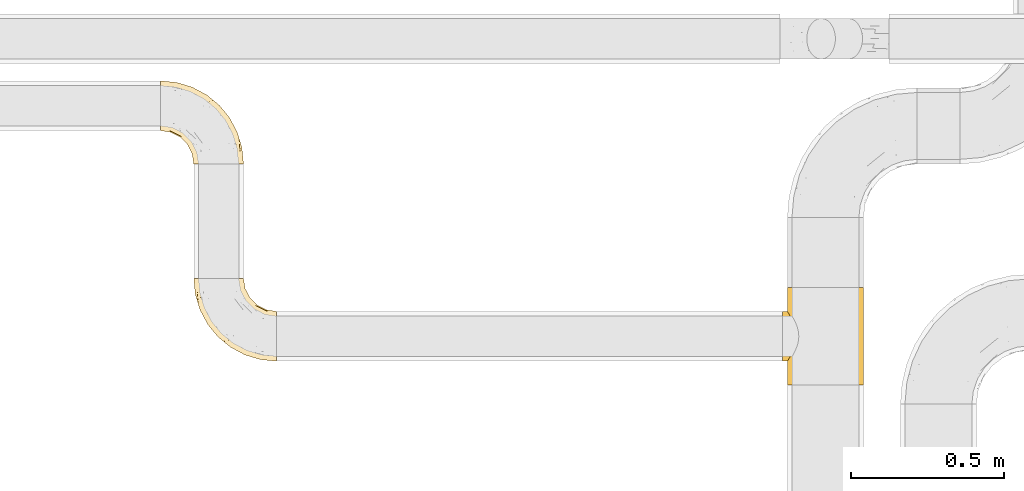
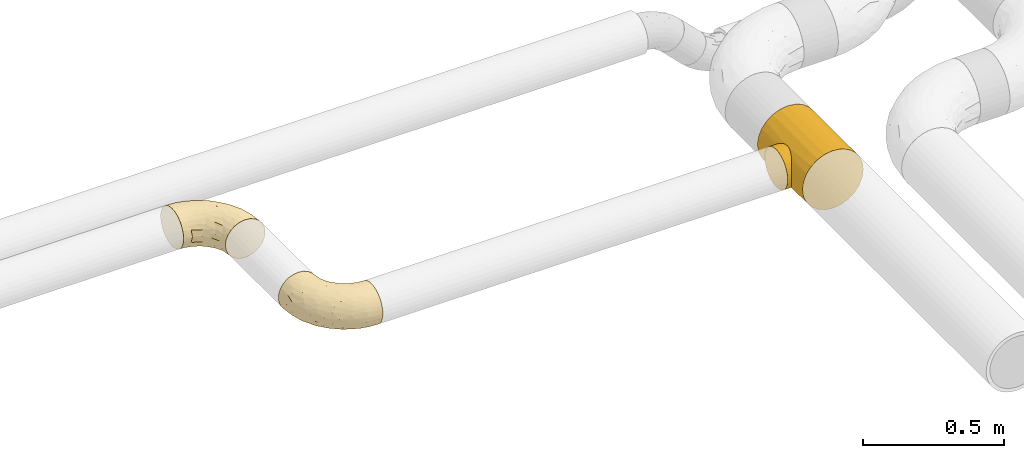
# One storey, part 37 of 93: 3 coverings.
"""IFC2X3 building model written with IfcOpenShell, lengths in millimetres."""

from ifc_helpers import new_model, entity, si_unit, converted_unit, derived_unit, direction, frame, origin, place, context, subcontext, project, spatial, faceted_brep, element, save


model = new_model("IFC2X3")

# Units and contexts
model_context = context("Model", 3, precision=0.01, world=origin(), true_north=direction((6.12303176911189e-17, 1.0)))
body_context = subcontext(model_context, "Body", "Model", "MODEL_VIEW")
ifc_project = project(units=[si_unit("LENGTHUNIT", "METRE", prefix="MILLI"), si_unit("AREAUNIT", "SQUARE_METRE"), si_unit("VOLUMEUNIT", "CUBIC_METRE"), converted_unit("PLANEANGLEUNIT", "DEGREE", entity("IfcRatioMeasure", 0.0174532925199433), si_unit("PLANEANGLEUNIT", "RADIAN"), dimensions=[0, 0, 0, 0, 0, 0, 0]), si_unit("MASSUNIT", "GRAM", prefix="KILO"), derived_unit("MASSDENSITYUNIT", [(si_unit("MASSUNIT", "GRAM", prefix="KILO"), 1), (si_unit("LENGTHUNIT", "METRE"), -3)]), derived_unit("MOMENTOFINERTIAUNIT", [(si_unit("LENGTHUNIT", "METRE"), 4)]), si_unit("TIMEUNIT", "SECOND"), si_unit("FREQUENCYUNIT", "HERTZ"), si_unit("THERMODYNAMICTEMPERATUREUNIT", "DEGREE_CELSIUS"), derived_unit("THERMALTRANSMITTANCEUNIT", [(si_unit("MASSUNIT", "GRAM", prefix="KILO"), 1), (si_unit("THERMODYNAMICTEMPERATUREUNIT", "KELVIN"), -1), (si_unit("TIMEUNIT", "SECOND"), -3)]), derived_unit("VOLUMETRICFLOWRATEUNIT", [(si_unit("LENGTHUNIT", "METRE"), 3), (si_unit("TIMEUNIT", "SECOND"), -1)]), derived_unit("MASSFLOWRATEUNIT", [(si_unit("MASSUNIT", "GRAM", prefix="KILO"), 1), (si_unit("TIMEUNIT", "SECOND"), -1)]), derived_unit("ROTATIONALFREQUENCYUNIT", [(si_unit("TIMEUNIT", "SECOND"), -1)]), si_unit("ELECTRICCURRENTUNIT", "AMPERE"), si_unit("ELECTRICVOLTAGEUNIT", "VOLT"), si_unit("POWERUNIT", "WATT"), si_unit("FORCEUNIT", "NEWTON", prefix="KILO"), si_unit("ILLUMINANCEUNIT", "LUX"), si_unit("LUMINOUSFLUXUNIT", "LUMEN"), si_unit("LUMINOUSINTENSITYUNIT", "CANDELA"), derived_unit("USERDEFINED", [(si_unit("MASSUNIT", "GRAM", prefix="KILO"), -1), (si_unit("LENGTHUNIT", "METRE"), -2), (si_unit("TIMEUNIT", "SECOND"), 3), (si_unit("LUMINOUSFLUXUNIT", "LUMEN"), 1)]), derived_unit("LINEARVELOCITYUNIT", [(si_unit("LENGTHUNIT", "METRE"), 1), (si_unit("TIMEUNIT", "SECOND"), -1)]), si_unit("PRESSUREUNIT", "PASCAL"), derived_unit("USERDEFINED", [(si_unit("LENGTHUNIT", "METRE"), -2), (si_unit("MASSUNIT", "GRAM", prefix="KILO"), 1), (si_unit("TIMEUNIT", "SECOND"), -2)]), derived_unit("LINEARFORCEUNIT", [(si_unit("MASSUNIT", "GRAM", prefix="KILO"), 1), (si_unit("LENGTHUNIT", "METRE"), 1), (si_unit("TIMEUNIT", "SECOND"), -2), (si_unit("LENGTHUNIT", "METRE"), -1)]), derived_unit("PLANARFORCEUNIT", [(si_unit("MASSUNIT", "GRAM", prefix="KILO"), 1), (si_unit("LENGTHUNIT", "METRE"), 1), (si_unit("TIMEUNIT", "SECOND"), -2), (si_unit("LENGTHUNIT", "METRE"), -2)])], contexts=[model_context])

# Site, building, storey
site_placement = place(None, origin())
site = spatial("IfcSite", under=ifc_project, at=site_placement, CompositionType="ELEMENT")
building_placement = place(site_placement, origin())
building = spatial("IfcBuilding", under=site, at=building_placement, CompositionType="ELEMENT")
storey_placement = place(building_placement, frame((0.0, 0.0, -4200.0)))
storey = spatial("IfcBuildingStorey", under=building, at=storey_placement, CompositionType="ELEMENT", Elevation=-4200.0)

# Coverings
covering_1_placement = place(storey_placement, frame((28161.81, 9063.14, 2716.9)))
element("IfcCovering", 1, at=covering_1_placement, inside=storey, Name=":ADSK_", ObjectType=":ADSK_", PredefinedType="INSULATION", context=body_context, shape_type="Brep", body=[
    faceted_brep([(1.6, 222.78, 158.39), (1.6, 236.87, 150.86), (1.6, 249.22, 140.72), (1.6, 259.36, 128.37), (1.6, 266.89, 114.28), (1.6, 271.53, 98.99), (1.6, 273.1, 83.1), (1.6, 271.53, 67.2), (1.6, 266.89, 51.91), (1.6, 259.36, 37.82), (1.6, 249.22, 25.47), (1.6, 236.87, 15.33), (1.6, 222.78, 7.8), (1.6, 207.49, 3.16), (1.6, 191.6, 1.6), (1.6, 175.7, 3.16), (1.6, 160.41, 7.8), (1.6, 146.32, 15.33), (1.6, 133.97, 25.47), (1.6, 123.83, 37.82), (1.6, 116.3, 51.91), (1.6, 111.66, 67.2), (1.6, 110.1, 83.1), (1.6, 111.66, 99.0), (1.6, 116.3, 114.28), (1.6, 123.83, 128.37), (1.6, 133.97, 140.72), (1.6, 146.32, 150.86), (1.6, 160.41, 158.39), (1.6, 175.7, 163.03), (1.6, 191.6, 164.6), (1.6, 207.5, 163.03), (112.87, 1.6, 62.0), (121.01, 1.6, 42.35), (133.97, 1.6, 25.47), (150.85, 1.6, 12.51), (170.5, 1.6, 4.37), (191.6, 1.6, 1.6), (212.69, 1.6, 4.37), (232.35, 1.6, 12.51), (249.22, 1.6, 25.47), (262.18, 1.6, 42.35), (270.32, 1.6, 62.0), (273.1, 1.6, 83.1), (270.32, 1.6, 104.19), (262.18, 1.6, 123.85), (249.22, 1.6, 140.72), (232.35, 1.6, 153.68), (212.69, 1.6, 161.82), (191.6, 1.6, 164.6), (170.5, 1.6, 161.82), (150.85, 1.6, 153.68), (133.97, 1.6, 140.72), (121.01, 1.6, 123.85), (112.87, 1.6, 104.19), (110.1, 1.6, 83.1), (259.24, 77.51, 104.67), (267.88, 54.56, 83.1), (252.43, 105.49, 83.1), (232.27, 109.47, 132.71), (203.25, 161.95, 128.57), (208.72, 138.06, 140.31), (161.26, 205.1, 127.0), (208.94, 168.59, 111.93), (171.1, 208.94, 107.33), (210.75, 172.96, 96.47), (56.09, 226.77, 153.13), (234.92, 122.99, 119.3), (237.78, 131.27, 101.32), (135.85, 206.95, 142.92), (90.98, 230.44, 142.61), (106.5, 210.46, 151.87), (203.21, 53.16, 162.56), (172.78, 84.03, 164.6), (186.83, 43.87, 164.6), (227.34, 152.43, 83.1), (107.06, 243.25, 117.97), (61.85, 257.44, 119.64), (100.97, 237.33, 131.15), (193.57, 193.57, 83.1), (152.43, 227.34, 83.1), (218.24, 63.71, 156.52), (227.74, 92.99, 144.21), (239.64, 42.41, 146.25), (250.37, 63.41, 130.43), (43.87, 186.83, 164.6), (78.77, 195.08, 162.51), (181.88, 122.49, 159.97), (192.35, 138.28, 151.26), (151.91, 181.92, 151.21), (261.16, 48.64, 117.68), (125.68, 185.11, 158.25), (120.31, 169.75, 163.04), (62.42, 263.05, 105.24), (114.22, 246.5, 100.78), (43.77, 241.49, 144.52), (175.87, 175.87, 141.87), (55.94, 250.34, 132.77), (105.49, 252.43, 83.1), (54.56, 267.88, 83.1), (84.03, 172.78, 164.6), (120.06, 150.14, 164.6), (150.14, 120.06, 164.6), (143.53, 32.61, 151.23), (124.28, 43.04, 137.69), (164.08, 41.06, 161.34), (63.41, 119.26, 141.27), (34.09, 127.92, 138.72), (50.98, 112.47, 127.05), (71.3, 90.5, 109.71), (35.12, 104.78, 83.1), (65.37, 89.37, 83.1), (103.16, 60.79, 120.43), (108.14, 76.89, 138.75), (82.77, 93.74, 129.2), (101.65, 138.12, 161.91), (76.68, 151.34, 161.43), (87.17, 129.05, 155.97), (149.53, 89.24, 162.57), (116.92, 116.92, 160.03), (116.45, 92.03, 151.82), (114.12, 29.57, 117.14), (32.67, 110.12, 109.48), (26.08, 141.41, 148.92), (54.1, 138.22, 151.93), (137.51, 68.2, 154.85), (108.77, 26.59, 98.92), (99.57, 52.67, 100.98), (89.37, 65.37, 83.1), (104.78, 35.12, 83.1), (90.24, 106.81, 145.5), (36.38, 155.99, 158.16), (57.28, 166.25, 162.97), (28.92, 171.98, 162.71), (83.96, 74.54, 98.76), (153.13, 62.85, 160.15), (24.92, 118.88, 124.12), (103.17, 111.86, 154.06), (137.51, 68.2, 11.34), (124.28, 43.04, 28.5), (108.14, 76.89, 27.44), (116.45, 92.03, 14.37), (108.77, 26.59, 67.27), (99.57, 52.67, 65.22), (50.98, 112.47, 39.14), (63.41, 119.26, 24.93), (82.77, 93.74, 36.99), (28.92, 171.98, 3.48), (71.3, 90.5, 56.48), (143.53, 32.61, 14.96), (164.08, 41.06, 4.85), (24.92, 118.88, 42.07), (34.09, 127.91, 27.47), (103.16, 60.79, 45.76), (83.96, 74.54, 67.43), (57.28, 166.25, 3.22), (36.38, 155.99, 8.03), (186.83, 43.87, 1.6), (114.12, 29.57, 49.05), (26.08, 141.41, 17.27), (32.67, 110.12, 56.71), (162.83, 68.35, 3.08), (149.53, 89.24, 3.62), (84.03, 172.78, 1.6), (120.06, 150.14, 1.6), (76.68, 151.34, 4.76), (150.14, 120.06, 1.6), (172.78, 84.03, 1.6), (90.24, 106.81, 20.69), (116.92, 116.92, 6.16), (54.1, 138.22, 14.26), (87.17, 129.05, 10.22), (101.65, 138.12, 4.28), (43.87, 186.83, 1.6), (102.74, 111.73, 12.35), (250.37, 63.41, 35.76), (90.98, 230.44, 23.58), (100.94, 237.34, 35.03), (141.5, 214.88, 34.03), (45.45, 260.65, 46.35), (195.08, 78.77, 3.68), (169.75, 120.31, 3.15), (185.11, 125.68, 7.94), (175.87, 175.87, 24.32), (190.61, 180.24, 41.48), (122.49, 181.88, 6.22), (75.94, 192.21, 2.91), (212.14, 166.39, 57.48), (215.84, 76.36, 10.43), (234.04, 104.7, 33.0), (227.74, 92.99, 21.98), (210.82, 138.7, 28.1), (252.63, 81.73, 47.91), (43.77, 241.49, 21.67), (171.1, 208.94, 58.86), (67.05, 225.32, 13.93), (234.92, 122.99, 46.89), (240.01, 126.09, 62.93), (239.64, 42.41, 19.94), (259.24, 77.51, 61.52), (124.28, 201.91, 15.08), (63.96, 210.82, 6.68), (114.23, 246.49, 65.41), (195.27, 138.52, 16.65), (159.59, 167.35, 11.53), (62.43, 263.05, 60.95), (55.94, 250.34, 33.42), (107.06, 243.25, 48.22)], [[[0, 1, 2, 3, 4, 5, 6, 7, 8, 9, 10, 11, 12, 13, 14, 15, 16, 17, 18, 19, 20, 21, 22, 23, 24, 25, 26, 27, 28, 29, 30, 31]], [[32, 33, 34, 35, 36, 37, 38, 39, 40, 41, 42, 43, 44, 45, 46, 47, 48, 49, 50, 51, 52, 53, 54, 55]], [[56, 57, 58]], [[57, 44, 43]], [[59, 60, 61]], [[62, 63, 64]], [[63, 65, 64]], [[1, 0, 66]], [[67, 68, 63]], [[69, 70, 71]], [[72, 73, 74]], [[75, 68, 58]], [[76, 77, 78]], [[64, 79, 80]], [[81, 48, 47]], [[82, 83, 84]], [[31, 85, 86]], [[71, 70, 66]], [[47, 83, 81]], [[87, 88, 89]], [[69, 62, 78]], [[49, 48, 72]], [[90, 44, 56]], [[48, 81, 72]], [[87, 91, 92]], [[93, 76, 94]], [[70, 95, 66]], [[88, 96, 89]], [[45, 84, 46]], [[2, 95, 97]], [[4, 93, 5]], [[98, 99, 93]], [[59, 84, 67]], [[3, 97, 77]], [[71, 86, 91]], [[4, 3, 77]], [[90, 84, 45]], [[99, 6, 5]], [[83, 47, 46]], [[95, 2, 1]], [[94, 80, 98]], [[100, 101, 92]], [[66, 31, 86]], [[60, 63, 62]], [[85, 31, 30]], [[102, 87, 92]], [[93, 77, 76]], [[91, 86, 92]], [[44, 57, 56]], [[86, 85, 100]], [[78, 97, 70]], [[87, 102, 73]], [[2, 97, 3]], [[67, 84, 90]], [[31, 66, 0]], [[93, 94, 98]], [[88, 81, 82]], [[99, 5, 93]], [[87, 73, 72]], [[66, 95, 1]], [[97, 95, 70]], [[86, 71, 66]], [[69, 89, 96]], [[89, 71, 91]], [[69, 96, 62]], [[60, 62, 96]], [[76, 62, 64]], [[71, 89, 69]], [[87, 89, 91]], [[81, 88, 87]], [[61, 88, 82]], [[61, 60, 96]], [[60, 67, 63]], [[68, 67, 56]], [[79, 65, 75]], [[58, 68, 56]], [[65, 68, 75]], [[64, 65, 79]], [[68, 65, 63]], [[76, 64, 94]], [[80, 94, 64]], [[100, 92, 86]], [[92, 101, 102]], [[88, 61, 96]], [[59, 61, 82]], [[84, 59, 82]], [[60, 59, 67]], [[87, 72, 81]], [[49, 72, 74]], [[84, 83, 46]], [[81, 83, 82]], [[69, 78, 70]], [[62, 76, 78]], [[4, 77, 93]], [[78, 77, 97]], [[44, 90, 45]], [[67, 90, 56]], [[103, 104, 52]], [[50, 49, 74]], [[50, 74, 105]], [[106, 107, 108]], [[109, 110, 111]], [[112, 113, 114]], [[104, 113, 112]], [[73, 105, 74]], [[115, 116, 117]], [[118, 119, 120]], [[104, 53, 52]], [[51, 103, 52]], [[53, 121, 54]], [[24, 23, 122]], [[123, 107, 124]], [[122, 109, 108]], [[125, 120, 113]], [[55, 54, 126]], [[102, 118, 73]], [[127, 126, 121]], [[128, 129, 127]], [[105, 51, 50]], [[102, 101, 119]], [[120, 130, 113]], [[26, 123, 27]], [[27, 131, 28]], [[132, 85, 133]], [[85, 29, 133]], [[134, 111, 128]], [[28, 133, 29]], [[30, 29, 85]], [[116, 131, 124]], [[135, 73, 118]], [[27, 123, 131]], [[110, 23, 22]], [[136, 122, 108]], [[24, 136, 25]], [[114, 108, 109]], [[119, 115, 117]], [[136, 107, 25]], [[128, 127, 134]], [[122, 110, 109]], [[104, 112, 121]], [[107, 106, 124]], [[107, 26, 25]], [[23, 110, 122]], [[101, 100, 116]], [[131, 132, 133]], [[105, 135, 103]], [[116, 124, 117]], [[122, 136, 24]], [[107, 136, 108]], [[28, 131, 133]], [[131, 116, 132]], [[126, 127, 129]], [[134, 112, 109]], [[107, 123, 26]], [[131, 123, 124]], [[104, 121, 53]], [[127, 121, 112]], [[105, 103, 51]], [[104, 103, 125]], [[116, 100, 132]], [[85, 132, 100]], [[106, 117, 124]], [[137, 130, 120]], [[114, 106, 108]], [[106, 130, 117]], [[119, 118, 102]], [[135, 118, 125]], [[125, 113, 104]], [[114, 113, 130]], [[114, 130, 106]], [[112, 114, 109]], [[118, 120, 125]], [[117, 137, 119]], [[55, 126, 129]], [[121, 126, 54]], [[112, 134, 127]], [[111, 134, 109]], [[119, 101, 115]], [[101, 116, 115]], [[103, 135, 125]], [[73, 135, 105]], [[130, 137, 117]], [[120, 119, 137]], [[138, 139, 140]], [[140, 141, 138]], [[55, 129, 142]], [[143, 142, 129]], [[144, 145, 146]], [[147, 16, 15]], [[110, 148, 111]], [[128, 143, 129]], [[149, 150, 35]], [[151, 152, 144]], [[153, 143, 154]], [[147, 155, 156]], [[35, 150, 36]], [[37, 36, 157]], [[35, 34, 149]], [[139, 33, 158]], [[159, 152, 18]], [[150, 157, 36]], [[140, 139, 153]], [[139, 34, 33]], [[110, 21, 160]], [[150, 161, 157]], [[20, 19, 151]], [[161, 138, 162]], [[110, 22, 21]], [[163, 164, 165]], [[166, 167, 162]], [[151, 160, 20]], [[140, 146, 168]], [[111, 148, 154]], [[164, 166, 169]], [[18, 152, 19]], [[170, 156, 165]], [[17, 159, 18]], [[158, 33, 32]], [[171, 165, 172]], [[155, 165, 156]], [[148, 110, 160]], [[170, 159, 156]], [[160, 144, 148]], [[15, 14, 173]], [[170, 171, 145]], [[149, 139, 138]], [[15, 173, 147]], [[144, 152, 145]], [[156, 17, 16]], [[165, 171, 170]], [[20, 160, 21]], [[171, 172, 169]], [[169, 166, 162]], [[152, 151, 19]], [[160, 151, 144]], [[155, 173, 163]], [[156, 16, 147]], [[154, 143, 128]], [[143, 153, 158]], [[156, 159, 17]], [[152, 159, 170]], [[158, 32, 142]], [[139, 158, 153]], [[139, 149, 34]], [[150, 149, 138]], [[173, 155, 147]], [[163, 165, 155]], [[174, 169, 141]], [[145, 171, 168]], [[170, 145, 152]], [[146, 145, 168]], [[161, 162, 167]], [[162, 138, 141]], [[146, 153, 148]], [[140, 168, 141]], [[153, 146, 140]], [[144, 146, 148]], [[174, 141, 168]], [[162, 141, 169]], [[158, 142, 143]], [[55, 142, 32]], [[111, 154, 128]], [[153, 154, 148]], [[165, 164, 172]], [[164, 169, 172]], [[157, 161, 167]], [[138, 161, 150]], [[168, 171, 174]], [[169, 174, 171]], [[41, 40, 175]], [[176, 177, 178]], [[9, 8, 179]], [[180, 181, 182]], [[157, 180, 37]], [[183, 178, 184]], [[164, 185, 181]], [[13, 186, 173]], [[187, 79, 75]], [[167, 166, 181]], [[186, 163, 173]], [[182, 188, 180]], [[57, 43, 42]], [[189, 190, 191]], [[164, 186, 185]], [[192, 41, 175]], [[193, 11, 10]], [[178, 194, 184]], [[12, 11, 195]], [[196, 187, 197]], [[40, 198, 175]], [[198, 40, 39]], [[58, 199, 197]], [[200, 185, 201]], [[163, 186, 164]], [[201, 185, 186]], [[202, 80, 194]], [[190, 203, 191]], [[201, 186, 13]], [[204, 185, 200]], [[201, 13, 12]], [[41, 199, 42]], [[195, 200, 201]], [[98, 205, 99]], [[57, 42, 199]], [[13, 173, 14]], [[58, 57, 199]], [[193, 206, 176]], [[80, 79, 194]], [[207, 205, 202]], [[196, 184, 187]], [[202, 205, 98]], [[205, 179, 8]], [[9, 206, 10]], [[207, 206, 179]], [[182, 203, 188]], [[6, 99, 7]], [[188, 38, 180]], [[203, 182, 204]], [[7, 205, 8]], [[37, 180, 38]], [[167, 180, 157]], [[7, 99, 205]], [[182, 181, 185]], [[11, 193, 195]], [[196, 191, 184]], [[175, 189, 192]], [[198, 188, 190]], [[38, 188, 39]], [[206, 193, 10]], [[195, 193, 176]], [[195, 176, 200]], [[12, 195, 201]], [[178, 200, 176]], [[185, 204, 182]], [[200, 183, 204]], [[203, 204, 183]], [[191, 203, 183]], [[188, 203, 190]], [[184, 191, 183]], [[190, 189, 175]], [[200, 178, 183]], [[184, 194, 187]], [[177, 176, 206]], [[194, 178, 207]], [[79, 187, 194]], [[197, 199, 192]], [[187, 75, 197]], [[58, 197, 75]], [[191, 196, 189]], [[192, 189, 196]], [[80, 202, 98]], [[194, 207, 202]], [[167, 181, 180]], [[181, 166, 164]], [[188, 198, 39]], [[175, 198, 190]], [[207, 179, 205]], [[9, 179, 206]], [[197, 192, 196]], [[41, 192, 199]], [[206, 207, 177]], [[207, 178, 177]]]),
])
covering_2_placement = place(storey_placement, frame((30199.78, 8340.0, 2673.9)))
element("IfcCovering", 2, at=covering_2_placement, inside=storey, Name=":ADSK_", ObjectType=":ADSK_", PredefinedType="INSULATION", context=body_context, shape_type="Brep", body=[
    faceted_brep([(247.82, 0.0, 63.85), (260.26, 0.0, 93.87), (264.5, 0.0, 126.1), (260.26, 0.0, 158.32), (247.82, 0.0, 188.35), (228.03, 0.0, 214.13), (202.25, 0.0, 233.92), (172.22, 0.0, 246.35), (140.0, 0.0, 250.6), (107.78, 0.0, 246.35), (77.75, 0.0, 233.92), (51.97, 0.0, 214.13), (32.18, 0.0, 188.35), (25.96, 0.0, 173.33), (19.74, 0.0, 158.32), (17.62, 0.0, 142.21), (15.5, 0.0, 126.1), (17.62, 0.0, 109.98), (19.74, 0.0, 93.87), (25.96, 0.0, 78.86), (32.18, 0.0, 63.85), (51.97, 0.0, 38.06), (77.75, 0.0, 18.28), (107.78, 0.0, 5.84), (140.0, 0.0, 1.6), (172.22, 0.0, 5.84), (202.25, 0.0, 18.28), (228.03, 0.0, 38.06), (140.0, 320.0, 250.6), (172.22, 320.0, 246.35), (202.25, 320.0, 233.92), (228.03, 320.0, 214.13), (247.82, 320.0, 188.35), (260.26, 320.0, 158.32), (264.5, 320.0, 126.1), (260.26, 320.0, 93.87), (247.82, 320.0, 63.85), (228.03, 320.0, 38.06), (202.25, 320.0, 18.28), (172.22, 320.0, 5.84), (140.0, 320.0, 1.6), (107.78, 320.0, 5.84), (77.75, 320.0, 18.28), (51.97, 320.0, 38.06), (32.18, 320.0, 63.85), (25.96, 320.0, 78.86), (19.74, 320.0, 93.87), (17.62, 320.0, 109.98), (15.5, 320.0, 126.1), (17.62, 320.0, 142.21), (19.74, 320.0, 158.32), (25.96, 320.0, 173.33), (32.18, 320.0, 188.35), (51.97, 320.0, 214.13), (77.75, 320.0, 233.92), (107.78, 320.0, 246.35), (45.88, 160.0, 207.6), (18.82, 236.33, 154.65), (16.36, 240.18, 140.69), (32.29, 212.37, 188.54), (37.31, 201.08, 196.48), (22.57, 89.78, 167.46), (41.69, 188.41, 202.48), (44.76, 174.57, 206.28), (44.76, 145.43, 206.28), (16.36, 79.82, 140.69), (41.69, 131.59, 202.48), (37.31, 118.92, 196.48), (27.22, 222.15, 178.82), (22.57, 230.22, 167.46), (15.5, 241.5, 126.1), (15.5, 78.5, 126.1), (32.29, 107.63, 188.54), (27.22, 97.85, 178.82), (18.82, 83.67, 154.65), (16.36, 240.18, 111.5), (16.36, 79.82, 111.5), (18.82, 236.33, 97.54), (27.22, 222.15, 73.37), (22.57, 230.22, 84.73), (18.82, 83.67, 97.54), (27.22, 97.85, 73.37), (22.57, 89.78, 84.73), (32.29, 107.63, 63.65), (32.29, 212.37, 63.65), (37.31, 201.08, 55.71), (44.76, 174.57, 45.91), (41.69, 188.41, 49.71), (45.88, 160.0, 44.6), (41.69, 131.59, 49.71), (44.76, 145.43, 45.91), (37.31, 118.92, 55.71), (0.0, 160.0, 207.6), (0.0, 181.09, 204.82), (0.0, 200.75, 196.68), (0.0, 217.63, 183.72), (0.0, 230.58, 166.85), (0.0, 238.72, 147.19), (0.0, 241.5, 126.1), (0.0, 238.72, 105.0), (0.0, 230.58, 85.35), (0.0, 217.63, 68.47), (0.0, 200.75, 55.51), (0.0, 181.09, 47.37), (0.0, 160.0, 44.6), (0.0, 138.91, 47.37), (0.0, 119.25, 55.51), (0.0, 102.37, 68.47), (0.0, 89.42, 85.35), (0.0, 81.28, 105.0), (0.0, 78.5, 126.1), (0.0, 81.28, 147.19), (0.0, 89.42, 166.85), (0.0, 102.37, 183.72), (0.0, 119.25, 196.68), (0.0, 138.91, 204.82)], [[[0, 1, 2, 3, 4, 5, 6, 7, 8, 9, 10, 11, 12, 13, 14, 15, 16, 17, 18, 19, 20, 21, 22, 23, 24, 25, 26, 27]], [[28, 29, 30, 31, 32, 33, 34, 35, 36, 37, 38, 39, 40, 41, 42, 43, 44, 45, 46, 47, 48, 49, 50, 51, 52, 53, 54, 55]], [[4, 32, 31, 5]], [[2, 34, 33, 3]], [[3, 33, 32, 4]], [[6, 30, 29, 7]], [[7, 29, 28, 8]], [[5, 31, 30, 6]], [[54, 10, 9, 55]], [[55, 9, 8, 28]], [[56, 54, 53]], [[57, 49, 58]], [[52, 59, 60]], [[61, 14, 13]], [[62, 63, 53]], [[60, 62, 53]], [[60, 53, 52]], [[53, 63, 56]], [[56, 11, 10]], [[56, 64, 11]], [[65, 16, 15]], [[66, 67, 11]], [[68, 51, 69]], [[64, 66, 11]], [[56, 10, 54]], [[11, 67, 12]], [[51, 50, 69]], [[68, 52, 51]], [[50, 57, 69]], [[48, 70, 58]], [[16, 65, 71]], [[50, 49, 57]], [[58, 49, 48]], [[72, 73, 12]], [[73, 13, 12]], [[13, 73, 61]], [[72, 12, 67]], [[65, 15, 74]], [[15, 14, 74]], [[74, 14, 61]], [[68, 59, 52]], [[70, 48, 75]], [[16, 71, 76]], [[77, 75, 47]], [[47, 46, 77]], [[44, 78, 45]], [[79, 45, 78]], [[46, 79, 77]], [[16, 76, 17]], [[80, 18, 17]], [[81, 20, 19]], [[19, 18, 82]], [[20, 81, 83]], [[82, 18, 80]], [[84, 78, 44]], [[84, 44, 85]], [[86, 87, 43]], [[85, 43, 87]], [[75, 48, 47]], [[42, 41, 23, 22]], [[88, 43, 42]], [[86, 43, 88]], [[44, 43, 85]], [[23, 41, 40, 24]], [[89, 90, 21]], [[80, 17, 76]], [[91, 21, 20]], [[79, 46, 45]], [[89, 21, 91]], [[88, 21, 90]], [[21, 88, 22]], [[42, 22, 88]], [[81, 19, 82]], [[91, 20, 83]], [[25, 39, 38, 26]], [[26, 38, 37, 27]], [[40, 39, 25, 24]], [[0, 36, 35, 1]], [[1, 35, 34, 2]], [[27, 37, 36, 0]], [[92, 93, 94, 95, 96, 97, 98, 99, 100, 101, 102, 103, 104, 105, 106, 107, 108, 109, 110, 111, 112, 113, 114, 115]], [[58, 70, 98]], [[58, 98, 97]], [[57, 97, 96]], [[57, 58, 97]], [[68, 69, 96]], [[57, 96, 69]], [[96, 95, 68]], [[95, 94, 59]], [[94, 93, 62]], [[63, 93, 92]], [[59, 94, 60]], [[93, 63, 62]], [[62, 60, 94]], [[63, 92, 56]], [[95, 59, 68]], [[64, 92, 115]], [[115, 114, 66]], [[72, 114, 113]], [[72, 67, 114]], [[56, 92, 64]], [[64, 115, 66]], [[114, 67, 66]], [[73, 113, 112]], [[111, 110, 65]], [[74, 112, 111]], [[61, 73, 112]], [[65, 74, 111]], [[71, 65, 110]], [[61, 112, 74]], [[113, 73, 72]], [[76, 71, 110]], [[76, 110, 109]], [[80, 109, 108]], [[80, 76, 109]], [[81, 82, 108]], [[80, 108, 82]], [[108, 107, 81]], [[83, 107, 106]], [[106, 105, 89]], [[104, 90, 105]], [[83, 106, 91]], [[105, 90, 89]], [[89, 91, 106]], [[90, 104, 88]], [[107, 83, 81]], [[86, 104, 103]], [[103, 102, 87]], [[84, 102, 101]], [[84, 85, 102]], [[88, 104, 86]], [[86, 103, 87]], [[102, 85, 87]], [[78, 101, 100]], [[100, 99, 77]], [[98, 75, 99]], [[79, 78, 100]], [[75, 77, 99]], [[70, 75, 98]], [[79, 100, 77]], [[101, 78, 84]]]),
])
covering_3_placement = place(storey_placement, frame((28270.31, 8416.9, 2716.9)))
element("IfcCovering", 3, at=covering_3_placement, inside=storey, Name=":ADSK_", ObjectType=":ADSK_", PredefinedType="INSULATION", context=body_context, shape_type="Brep", body=[
    faceted_brep([(273.1, 51.91, 158.39), (273.1, 37.82, 150.86), (273.1, 25.47, 140.72), (273.1, 15.33, 128.37), (273.1, 7.8, 114.28), (273.1, 3.16, 98.99), (273.1, 1.6, 83.1), (273.1, 3.16, 67.2), (273.1, 7.8, 51.91), (273.1, 15.33, 37.82), (273.1, 25.47, 25.47), (273.1, 37.82, 15.33), (273.1, 51.91, 7.8), (273.1, 67.2, 3.16), (273.1, 83.1, 1.6), (273.1, 99.0, 3.16), (273.1, 114.28, 7.8), (273.1, 128.37, 15.33), (273.1, 140.72, 25.47), (273.1, 150.86, 37.82), (273.1, 158.39, 51.91), (273.1, 163.03, 67.2), (273.1, 164.6, 83.1), (273.1, 163.03, 99.0), (273.1, 158.39, 114.28), (273.1, 150.86, 128.37), (273.1, 140.72, 140.72), (273.1, 128.37, 150.86), (273.1, 114.28, 158.39), (273.1, 98.99, 163.03), (273.1, 83.1, 164.6), (273.1, 67.2, 163.03), (161.82, 273.1, 62.0), (153.68, 273.1, 42.35), (140.72, 273.1, 25.47), (123.85, 273.1, 12.51), (104.19, 273.1, 4.37), (83.1, 273.1, 1.6), (62.0, 273.1, 4.37), (42.35, 273.1, 12.51), (25.47, 273.1, 25.47), (12.51, 273.1, 42.35), (4.37, 273.1, 62.0), (1.6, 273.1, 83.1), (4.37, 273.1, 104.19), (12.51, 273.1, 123.85), (25.47, 273.1, 140.72), (42.35, 273.1, 153.68), (62.0, 273.1, 161.82), (83.1, 273.1, 164.6), (104.19, 273.1, 161.82), (123.85, 273.1, 153.68), (140.72, 273.1, 140.72), (153.68, 273.1, 123.85), (161.82, 273.1, 104.19), (164.6, 273.1, 83.1), (15.45, 197.18, 104.67), (6.81, 220.13, 83.1), (22.26, 169.2, 83.1), (42.42, 165.22, 132.71), (71.44, 112.74, 128.57), (65.97, 136.63, 140.31), (113.44, 69.59, 127.0), (65.75, 106.1, 111.93), (103.59, 65.75, 107.33), (63.94, 101.73, 96.47), (218.6, 47.92, 153.13), (39.77, 151.7, 119.3), (36.91, 143.42, 101.32), (138.84, 67.74, 142.92), (183.71, 44.25, 142.61), (168.19, 64.23, 151.87), (71.48, 221.53, 162.56), (101.91, 190.66, 164.6), (87.86, 230.82, 164.6), (47.35, 122.26, 83.1), (167.63, 31.44, 117.97), (212.84, 17.25, 119.64), (173.72, 37.36, 131.15), (81.12, 81.12, 83.1), (122.26, 47.35, 83.1), (56.45, 210.98, 156.52), (46.95, 181.7, 144.21), (35.05, 232.28, 146.25), (24.32, 211.28, 130.43), (230.82, 87.86, 164.6), (195.92, 79.61, 162.51), (92.81, 152.2, 159.97), (82.34, 136.41, 151.26), (122.78, 92.77, 151.21), (13.53, 226.05, 117.68), (149.02, 89.58, 158.25), (154.38, 104.94, 163.04), (212.27, 11.64, 105.24), (160.47, 28.2, 100.78), (230.92, 33.2, 144.52), (98.82, 98.82, 141.87), (218.75, 24.35, 132.77), (169.2, 22.26, 83.1), (220.13, 6.81, 83.1), (190.66, 101.91, 164.6), (154.63, 124.55, 164.6), (124.55, 154.63, 164.6), (131.16, 242.08, 151.23), (150.42, 231.65, 137.69), (110.62, 233.63, 161.34), (211.28, 155.43, 141.27), (240.6, 146.77, 138.72), (223.71, 162.22, 127.05), (203.39, 184.19, 109.71), (239.57, 169.91, 83.1), (209.32, 185.32, 83.1), (171.53, 213.9, 120.43), (166.55, 197.8, 138.75), (191.93, 180.95, 129.2), (173.04, 136.57, 161.91), (198.01, 123.35, 161.43), (187.52, 145.64, 155.97), (125.16, 185.45, 162.57), (157.77, 157.77, 160.03), (158.24, 182.66, 151.82), (160.57, 245.12, 117.14), (242.02, 164.57, 109.48), (248.61, 133.28, 148.92), (220.59, 136.47, 151.93), (137.18, 206.49, 154.85), (165.92, 248.1, 98.92), (175.12, 222.02, 100.98), (185.32, 209.32, 83.1), (169.91, 239.57, 83.1), (184.45, 167.88, 145.5), (238.32, 118.7, 158.16), (217.41, 108.44, 162.97), (245.77, 102.71, 162.71), (190.73, 200.15, 98.76), (121.56, 211.84, 160.15), (249.77, 155.81, 124.12), (171.52, 162.83, 154.06), (137.18, 206.49, 11.34), (150.42, 231.65, 28.5), (166.55, 197.8, 27.44), (158.24, 182.66, 14.37), (165.92, 248.1, 67.27), (175.12, 222.02, 65.22), (223.71, 162.22, 39.14), (211.28, 155.43, 24.93), (191.92, 180.95, 36.99), (245.77, 102.71, 3.48), (203.4, 184.19, 56.48), (131.16, 242.08, 14.96), (110.62, 233.63, 4.85), (249.77, 155.81, 42.07), (240.6, 146.78, 27.47), (171.53, 213.9, 45.76), (190.73, 200.15, 67.43), (217.41, 108.44, 3.22), (238.31, 118.7, 8.03), (87.86, 230.82, 1.6), (160.57, 245.12, 49.05), (248.61, 133.28, 17.27), (242.02, 164.57, 56.71), (111.86, 206.34, 3.08), (125.16, 185.45, 3.62), (190.66, 101.91, 1.6), (154.63, 124.55, 1.6), (198.01, 123.35, 4.76), (124.55, 154.63, 1.6), (101.91, 190.66, 1.6), (184.45, 167.88, 20.69), (157.77, 157.77, 6.16), (220.59, 136.47, 14.26), (187.52, 145.64, 10.22), (173.04, 136.57, 4.28), (230.82, 87.86, 1.6), (171.95, 162.96, 12.35), (24.32, 211.28, 35.76), (183.71, 44.25, 23.58), (173.75, 37.35, 35.03), (133.19, 59.81, 34.03), (229.24, 14.04, 46.35), (79.61, 195.92, 3.68), (104.94, 154.38, 3.15), (89.58, 149.02, 7.94), (98.82, 98.82, 24.32), (84.08, 94.45, 41.48), (152.2, 92.81, 6.22), (198.75, 82.48, 2.91), (62.55, 108.3, 57.48), (58.85, 198.33, 10.43), (40.65, 169.99, 33.0), (46.95, 181.7, 21.98), (63.87, 135.99, 28.1), (22.06, 192.96, 47.91), (230.92, 33.21, 21.67), (103.59, 65.75, 58.86), (207.65, 49.37, 13.93), (39.77, 151.7, 46.89), (34.68, 148.6, 62.93), (35.05, 232.28, 19.94), (15.45, 197.18, 61.52), (150.41, 72.78, 15.08), (210.73, 63.87, 6.68), (160.46, 28.2, 65.41), (79.42, 136.17, 16.65), (115.1, 107.34, 11.53), (212.26, 11.64, 60.95), (218.75, 24.35, 33.42), (167.63, 31.44, 48.22)], [[[0, 1, 2, 3, 4, 5, 6, 7, 8, 9, 10, 11, 12, 13, 14, 15, 16, 17, 18, 19, 20, 21, 22, 23, 24, 25, 26, 27, 28, 29, 30, 31]], [[32, 33, 34, 35, 36, 37, 38, 39, 40, 41, 42, 43, 44, 45, 46, 47, 48, 49, 50, 51, 52, 53, 54, 55]], [[56, 57, 58]], [[57, 44, 43]], [[59, 60, 61]], [[62, 63, 64]], [[63, 65, 64]], [[1, 0, 66]], [[67, 68, 63]], [[69, 70, 71]], [[72, 73, 74]], [[75, 68, 58]], [[76, 77, 78]], [[64, 79, 80]], [[81, 48, 47]], [[82, 83, 84]], [[31, 85, 86]], [[71, 70, 66]], [[47, 83, 81]], [[87, 88, 89]], [[69, 62, 78]], [[49, 48, 72]], [[90, 44, 56]], [[48, 81, 72]], [[87, 91, 92]], [[93, 76, 94]], [[70, 95, 66]], [[88, 96, 89]], [[45, 84, 46]], [[2, 95, 97]], [[4, 93, 5]], [[98, 99, 93]], [[59, 84, 67]], [[3, 97, 77]], [[71, 86, 91]], [[4, 3, 77]], [[90, 84, 45]], [[99, 6, 5]], [[83, 47, 46]], [[95, 2, 1]], [[94, 80, 98]], [[100, 101, 92]], [[66, 31, 86]], [[60, 63, 62]], [[85, 31, 30]], [[102, 87, 92]], [[93, 77, 76]], [[91, 86, 92]], [[44, 57, 56]], [[86, 85, 100]], [[78, 97, 70]], [[87, 102, 73]], [[2, 97, 3]], [[67, 84, 90]], [[31, 66, 0]], [[93, 94, 98]], [[88, 81, 82]], [[99, 5, 93]], [[87, 73, 72]], [[66, 95, 1]], [[97, 95, 70]], [[86, 71, 66]], [[69, 89, 96]], [[89, 71, 91]], [[69, 96, 62]], [[60, 62, 96]], [[76, 62, 64]], [[71, 89, 69]], [[87, 89, 91]], [[81, 88, 87]], [[61, 88, 82]], [[61, 60, 96]], [[60, 67, 63]], [[68, 67, 56]], [[79, 65, 75]], [[58, 68, 56]], [[65, 68, 75]], [[64, 65, 79]], [[68, 65, 63]], [[76, 64, 94]], [[80, 94, 64]], [[100, 92, 86]], [[92, 101, 102]], [[88, 61, 96]], [[59, 61, 82]], [[84, 59, 82]], [[60, 59, 67]], [[87, 72, 81]], [[49, 72, 74]], [[84, 83, 46]], [[81, 83, 82]], [[69, 78, 70]], [[62, 76, 78]], [[4, 77, 93]], [[78, 77, 97]], [[44, 90, 45]], [[67, 90, 56]], [[103, 104, 52]], [[50, 49, 74]], [[50, 74, 105]], [[106, 107, 108]], [[109, 110, 111]], [[112, 113, 114]], [[104, 113, 112]], [[73, 105, 74]], [[115, 116, 117]], [[118, 119, 120]], [[104, 53, 52]], [[51, 103, 52]], [[53, 121, 54]], [[24, 23, 122]], [[123, 107, 124]], [[122, 109, 108]], [[125, 120, 113]], [[55, 54, 126]], [[102, 118, 73]], [[127, 126, 121]], [[128, 129, 127]], [[105, 51, 50]], [[102, 101, 119]], [[120, 130, 113]], [[26, 123, 27]], [[27, 131, 28]], [[132, 85, 133]], [[85, 29, 133]], [[134, 111, 128]], [[28, 133, 29]], [[30, 29, 85]], [[116, 131, 124]], [[135, 73, 118]], [[27, 123, 131]], [[110, 23, 22]], [[136, 122, 108]], [[24, 136, 25]], [[114, 108, 109]], [[119, 115, 117]], [[136, 107, 25]], [[128, 127, 134]], [[122, 110, 109]], [[104, 112, 121]], [[107, 106, 124]], [[107, 26, 25]], [[23, 110, 122]], [[101, 100, 116]], [[131, 132, 133]], [[105, 135, 103]], [[116, 124, 117]], [[122, 136, 24]], [[107, 136, 108]], [[28, 131, 133]], [[131, 116, 132]], [[126, 127, 129]], [[134, 112, 109]], [[107, 123, 26]], [[131, 123, 124]], [[104, 121, 53]], [[127, 121, 112]], [[105, 103, 51]], [[104, 103, 125]], [[116, 100, 132]], [[85, 132, 100]], [[106, 117, 124]], [[137, 130, 120]], [[114, 106, 108]], [[106, 130, 117]], [[119, 118, 102]], [[135, 118, 125]], [[125, 113, 104]], [[114, 113, 130]], [[114, 130, 106]], [[112, 114, 109]], [[118, 120, 125]], [[117, 137, 119]], [[55, 126, 129]], [[121, 126, 54]], [[112, 134, 127]], [[111, 134, 109]], [[119, 101, 115]], [[101, 116, 115]], [[103, 135, 125]], [[73, 135, 105]], [[130, 137, 117]], [[120, 119, 137]], [[138, 139, 140]], [[140, 141, 138]], [[55, 129, 142]], [[143, 142, 129]], [[144, 145, 146]], [[147, 16, 15]], [[110, 148, 111]], [[128, 143, 129]], [[149, 150, 35]], [[151, 152, 144]], [[153, 143, 154]], [[147, 155, 156]], [[35, 150, 36]], [[37, 36, 157]], [[35, 34, 149]], [[139, 33, 158]], [[159, 152, 18]], [[150, 157, 36]], [[140, 139, 153]], [[139, 34, 33]], [[110, 21, 160]], [[150, 161, 157]], [[20, 19, 151]], [[161, 138, 162]], [[110, 22, 21]], [[163, 164, 165]], [[166, 167, 162]], [[151, 160, 20]], [[140, 146, 168]], [[111, 148, 154]], [[164, 166, 169]], [[18, 152, 19]], [[170, 156, 165]], [[17, 159, 18]], [[158, 33, 32]], [[171, 165, 172]], [[155, 165, 156]], [[148, 110, 160]], [[170, 159, 156]], [[160, 144, 148]], [[15, 14, 173]], [[170, 171, 145]], [[149, 139, 138]], [[15, 173, 147]], [[144, 152, 145]], [[156, 17, 16]], [[165, 171, 170]], [[20, 160, 21]], [[171, 172, 169]], [[169, 166, 162]], [[152, 151, 19]], [[160, 151, 144]], [[155, 173, 163]], [[156, 16, 147]], [[154, 143, 128]], [[143, 153, 158]], [[156, 159, 17]], [[152, 159, 170]], [[158, 32, 142]], [[139, 158, 153]], [[139, 149, 34]], [[150, 149, 138]], [[173, 155, 147]], [[163, 165, 155]], [[174, 169, 141]], [[145, 171, 168]], [[170, 145, 152]], [[146, 145, 168]], [[161, 162, 167]], [[162, 138, 141]], [[146, 153, 148]], [[140, 168, 141]], [[153, 146, 140]], [[144, 146, 148]], [[174, 141, 168]], [[162, 141, 169]], [[158, 142, 143]], [[55, 142, 32]], [[111, 154, 128]], [[153, 154, 148]], [[165, 164, 172]], [[164, 169, 172]], [[157, 161, 167]], [[138, 161, 150]], [[168, 171, 174]], [[169, 174, 171]], [[41, 40, 175]], [[176, 177, 178]], [[9, 8, 179]], [[180, 181, 182]], [[157, 180, 37]], [[183, 178, 184]], [[164, 185, 181]], [[13, 186, 173]], [[187, 79, 75]], [[167, 166, 181]], [[186, 163, 173]], [[182, 188, 180]], [[57, 43, 42]], [[189, 190, 191]], [[164, 186, 185]], [[192, 41, 175]], [[193, 11, 10]], [[178, 194, 184]], [[12, 11, 195]], [[196, 187, 197]], [[40, 198, 175]], [[198, 40, 39]], [[58, 199, 197]], [[200, 185, 201]], [[163, 186, 164]], [[201, 185, 186]], [[202, 80, 194]], [[190, 203, 191]], [[201, 186, 13]], [[204, 185, 200]], [[201, 13, 12]], [[41, 199, 42]], [[195, 200, 201]], [[98, 205, 99]], [[57, 42, 199]], [[13, 173, 14]], [[58, 57, 199]], [[193, 206, 176]], [[80, 79, 194]], [[207, 205, 202]], [[196, 184, 187]], [[202, 205, 98]], [[205, 179, 8]], [[9, 206, 10]], [[207, 206, 179]], [[182, 203, 188]], [[6, 99, 7]], [[188, 38, 180]], [[203, 182, 204]], [[7, 205, 8]], [[37, 180, 38]], [[167, 180, 157]], [[7, 99, 205]], [[182, 181, 185]], [[11, 193, 195]], [[196, 191, 184]], [[175, 189, 192]], [[198, 188, 190]], [[38, 188, 39]], [[206, 193, 10]], [[195, 193, 176]], [[195, 176, 200]], [[12, 195, 201]], [[178, 200, 176]], [[185, 204, 182]], [[200, 183, 204]], [[203, 204, 183]], [[191, 203, 183]], [[188, 203, 190]], [[184, 191, 183]], [[190, 189, 175]], [[200, 178, 183]], [[184, 194, 187]], [[177, 176, 206]], [[194, 178, 207]], [[79, 187, 194]], [[197, 199, 192]], [[187, 75, 197]], [[58, 197, 75]], [[191, 196, 189]], [[192, 189, 196]], [[80, 202, 98]], [[194, 207, 202]], [[167, 181, 180]], [[181, 166, 164]], [[188, 198, 39]], [[175, 198, 190]], [[207, 179, 205]], [[9, 179, 206]], [[197, 192, 196]], [[41, 192, 199]], [[206, 207, 177]], [[207, 178, 177]]]),
])

save(model, "model.ifc")
